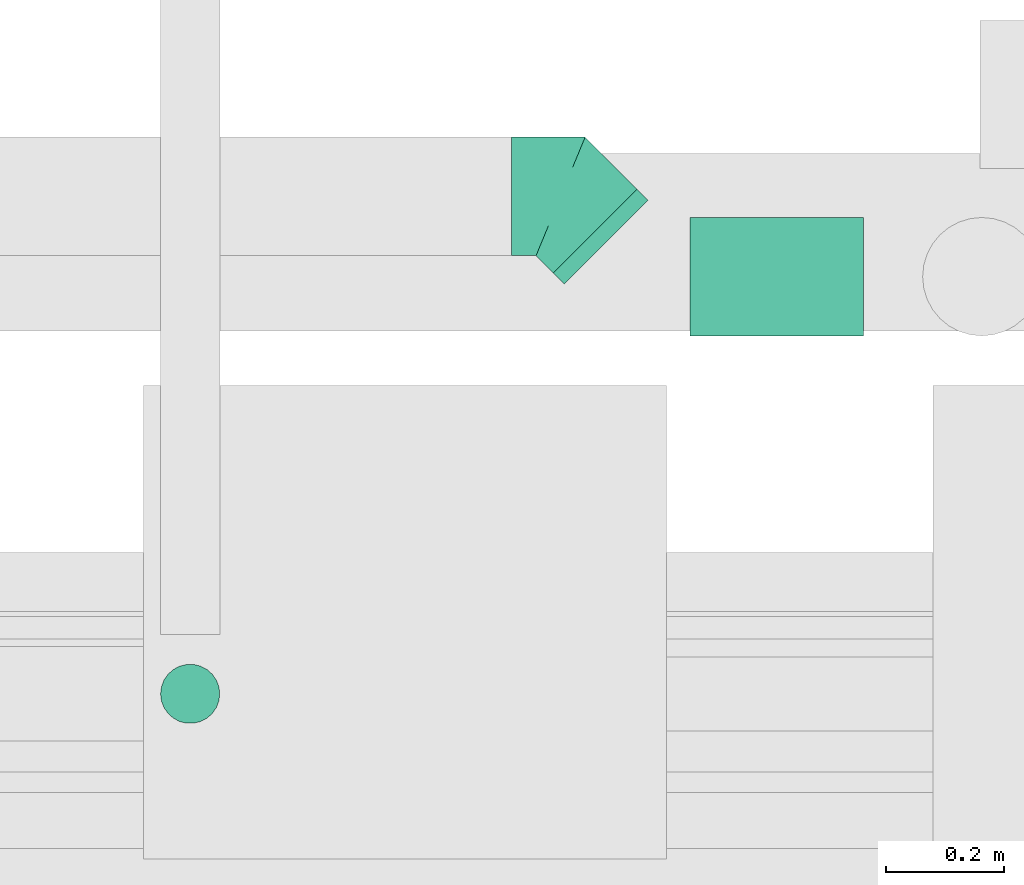
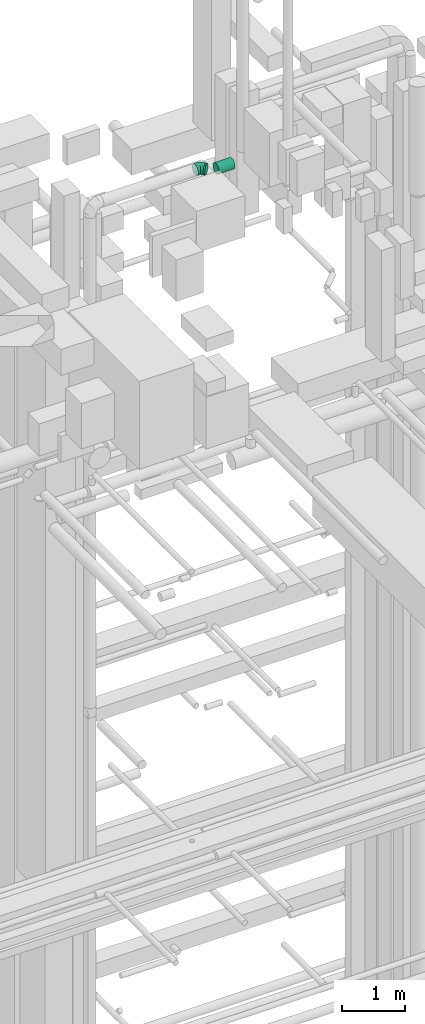
# One storey, part 131 of 337: 3 flow segments, 1 flow fitting.
"""IFC2X3 building model written with IfcOpenShell, lengths in millimetres."""

import ifcopenshell
import ifcopenshell.guid

model = None  # the IFC model being written
_history = None  # IfcOwnerHistory: only IFC2X3 demands one
_inside = {}  # id of a spatial element -> (the spatial element, [elements in it])
_under = {}  # id of a project, library or spatial element -> (it, [spatial elements below it])
_declared = {}  # id of a project -> (the project, [libraries it declares])
_typed = {}  # id of a type object -> (the type object, [elements of that type])
_made_of = {}  # id of a material, layer set ... -> (it, [elements and type objects made of it])


def new_model(schema):
    """Start an empty IFC model of exactly this schema.

    Asked for "IFC4X3", IfcOpenShell would pick the latest addendum, in which some entities
    have other attributes; the version numbers below select the first issue.
    IFC2X3 requires an IfcOwnerHistory on every rooted entity: one is made here for all.
    """
    global model, _history
    if schema == "IFC4X3":
        model = ifcopenshell.file(schema_version=(4, 3, 0, 0))
    else:
        model = ifcopenshell.file(schema=schema)
    _inside.clear()
    _under.clear()
    _declared.clear()
    _typed.clear()
    _made_of.clear()
    _history = None
    if model.schema == "IFC2X3":
        org = make("IfcOrganization", Name="unknown")
        user = make(
            "IfcPersonAndOrganization",
            ThePerson=make("IfcPerson", FamilyName="unknown"),
            TheOrganization=org,
        )
        app = make(
            "IfcApplication",
            ApplicationDeveloper=org,
            Version="unknown",
            ApplicationFullName="unknown",
            ApplicationIdentifier="unknown",
        )
        _history = make(
            "IfcOwnerHistory",
            OwningUser=user,
            OwningApplication=app,
            ChangeAction="ADDED",
            CreationDate=0,
        )
    return model


def make(cls, **values):
    """One entity of the class cls with the attributes given. An attribute that is None is left unset."""
    return model.create_entity(
        cls, **{name: value for name, value in values.items() if value is not None}
    )


def entity(cls, *values):
    """Any entity or typed value of the class cls, its attributes in the order of the schema. None: left unset."""
    e = model.create_entity(cls)
    for i, value in enumerate(values):
        if value is not None:
            e[i] = value
    return e


def rooted(cls, **values):
    """An entity with a GlobalId (a new one), such as an element, a storey or a relation."""
    return make(cls, GlobalId=ifcopenshell.guid.new(), OwnerHistory=_history, **values)


def si_unit(unit_type, name, prefix=None):
    """IfcSIUnit, for example si_unit("LENGTHUNIT", "METRE", prefix="MILLI")."""
    return make("IfcSIUnit", UnitType=unit_type, Prefix=prefix, Name=name)


def converted_unit(unit_type, name, factor, base, dimensions=None, offset=None):
    """IfcConversionBasedUnit, such as the inch: factor (a typed value) times the base unit."""
    return make(
        "IfcConversionBasedUnit"
        if offset is None
        else "IfcConversionBasedUnitWithOffset",
        ConversionOffset=offset,
        Dimensions=None
        if dimensions is None
        else entity("IfcDimensionalExponents", *dimensions),
        UnitType=unit_type,
        Name=name,
        ConversionFactor=make(
            "IfcMeasureWithUnit", ValueComponent=factor, UnitComponent=base
        ),
    )


def derived_unit(unit_type, elements):
    """IfcDerivedUnit: a product of units, each with its exponent."""
    return make(
        "IfcDerivedUnit",
        Elements=[
            make("IfcDerivedUnitElement", Unit=unit, Exponent=power)
            for unit, power in elements
        ],
        UnitType=unit_type,
    )


def assignment(units):
    """IfcUnitAssignment: the units of a project."""
    return None if units is None else make("IfcUnitAssignment", Units=units)


def point(xyz):
    """IfcCartesianPoint."""
    return None if xyz is None else make("IfcCartesianPoint", Coordinates=xyz)


def direction(xyz):
    """IfcDirection."""
    return None if xyz is None else make("IfcDirection", DirectionRatios=xyz)


def frame(location, z_axis=None, x_axis=None):
    """IfcAxis2Placement3D, a coordinate frame: its origin and axes. An axis left out is left unset."""
    return make(
        "IfcAxis2Placement3D",
        Location=point(location),
        Axis=direction(z_axis),
        RefDirection=direction(x_axis),
    )


def frame_2d(location, x_axis=None):
    """IfcAxis2Placement2D, a coordinate frame in the plane: its origin and x axis."""
    return make(
        "IfcAxis2Placement2D", Location=point(location), RefDirection=direction(x_axis)
    )


def origin():
    """The frame at (0, 0, 0) with its axes left unset."""
    return frame((0.0, 0.0, 0.0))


def origin_2d_with_axis():
    """The frame at (0, 0) in the plane with the x axis (1, 0) written out."""
    return frame_2d((0.0, 0.0), x_axis=(1.0, 0.0))


def place(relative_to, where):
    """IfcLocalPlacement: puts the frame where relative to a parent placement (None: the world)."""
    return make(
        "IfcLocalPlacement", PlacementRelTo=relative_to, RelativePlacement=where
    )


def context(
    kind, dimensions, precision=None, world=None, true_north=None, identifier=None
):
    """IfcGeometricRepresentationContext, for example the 3D "Model" context."""
    return make(
        "IfcGeometricRepresentationContext",
        ContextIdentifier=identifier,
        ContextType=kind,
        CoordinateSpaceDimension=dimensions,
        Precision=precision,
        WorldCoordinateSystem=world,
        TrueNorth=true_north,
    )


def subcontext(parent, identifier, kind, view, scale=None):
    """IfcGeometricRepresentationSubContext, for example "Body" below "Model"."""
    return make(
        "IfcGeometricRepresentationSubContext",
        ContextIdentifier=identifier,
        ContextType=kind,
        ParentContext=parent,
        TargetScale=scale,
        TargetView=view,
    )


def project(units=None, contexts=None):
    """IfcProject with its units and contexts."""
    return rooted(
        "IfcProject",
        Name="project",
        RepresentationContexts=contexts,
        UnitsInContext=assignment(units),
    )


def spatial(cls, under=None, at=None, **own):
    """A site, building, storey or space (cls), placed at a placement, below another one or the project."""
    s = rooted(cls, ObjectPlacement=at, **own)
    if under is not None:
        _under.setdefault(under.id(), (under, []))[1].append(s)
    return s


def profile(cls, at=None, kind="AREA", **sizes):
    """A parametric profile (cls). Its sizes go by their IFC names, for example OverallWidth=200.0."""
    return make(cls, ProfileType=kind, Position=at, **sizes)


def circle(**sizes):
    """IfcCircleProfileDef."""
    return profile("IfcCircleProfileDef", **sizes)


def extrude(swept, where, along, depth):
    """IfcExtrudedAreaSolid: the profile swept, set in the frame where, extruded along a direction by depth."""
    return make(
        "IfcExtrudedAreaSolid",
        SweptArea=swept,
        Position=where,
        ExtrudedDirection=direction(along),
        Depth=depth,
    )


def faces_of(points, faces, orient=None, outer=None):
    """IfcFace entities. A face is a list of loops; a loop is a list of indices into points, from 0.

    orient and outer hold one flag for each loop. By default every Orientation is true, the
    first loop of a face is its IfcFaceOuterBound and the others are IfcFaceBound.
    """
    made = []
    for i, loops in enumerate(faces):
        bounds = []
        for j, loop in enumerate(loops):
            is_outer = j == 0 if outer is None else outer[i][j]
            bounds.append(
                make(
                    "IfcFaceOuterBound" if is_outer else "IfcFaceBound",
                    Bound=make("IfcPolyLoop", Polygon=[points[k] for k in loop]),
                    Orientation=True if orient is None else orient[i][j],
                )
            )
        made.append(make("IfcFace", Bounds=bounds))
    return made


def faceted_brep(points, faces, orient=None, outer=None, voids=None):
    """IfcFacetedBrep: a solid bounded by flat faces; with voids (closed shells), ...WithVoids."""
    shared = [point(p) for p in points]
    hull = make("IfcClosedShell", CfsFaces=faces_of(shared, faces, orient, outer))
    if voids is None:
        return make("IfcFacetedBrep", Outer=hull)
    return make(
        "IfcFacetedBrepWithVoids",
        Outer=hull,
        Voids=[
            make(cls, CfsFaces=faces_of(shared, fs, o, b)) for cls, fs, o, b in voids
        ],
    )


def shape(context_of_items, identifier, shape_type, items):
    """IfcShapeRepresentation: the items that make up one representation, for example the "Body"."""
    return make(
        "IfcShapeRepresentation",
        ContextOfItems=context_of_items,
        RepresentationIdentifier=identifier,
        RepresentationType=shape_type,
        Items=items,
    )


def source(mapping_origin, context_of_items, identifier, shape_type, items):
    """IfcRepresentationMap: a shape defined once, which mapped items show again and again."""
    return make(
        "IfcRepresentationMap",
        MappingOrigin=mapping_origin,
        MappedRepresentation=shape(context_of_items, identifier, shape_type, items),
    )


def transform(
    local_origin,
    x_axis=None,
    y_axis=None,
    z_axis=None,
    scale=None,
    scale2=None,
    scale3=None,
    uniform=True,
):
    """IfcCartesianTransformationOperator3D, or its non-uniform kind. x_axis, y_axis, z_axis: its Axis1, 2, 3."""
    if uniform:
        return make(
            "IfcCartesianTransformationOperator3D",
            Axis1=direction(x_axis),
            Axis2=direction(y_axis),
            LocalOrigin=point(local_origin),
            Scale=scale,
            Axis3=direction(z_axis),
        )
    return make(
        "IfcCartesianTransformationOperator3DnonUniform",
        Axis1=direction(x_axis),
        Axis2=direction(y_axis),
        LocalOrigin=point(local_origin),
        Scale=scale,
        Axis3=direction(z_axis),
        Scale2=scale2,
        Scale3=scale3,
    )


def mapped(mapping_source, mapping_target):
    """IfcMappedItem: shows the shape of a source again, moved by a transform."""
    return make(
        "IfcMappedItem", MappingSource=mapping_source, MappingTarget=mapping_target
    )


def material(Name=None, Category=None):
    """IfcMaterial."""
    return make("IfcMaterial", Name=Name, Category=Category)


def made_of(thing, what):
    """Note that an element or type object is made of a material, layer set ...; save() writes the relation."""
    if what is not None:
        _made_of.setdefault(what.id(), (what, []))[1].append(thing)
    return thing


def type_object(cls, material=None, **own):
    """A type object (cls), such as IfcWallType, which elements share."""
    return made_of(rooted(cls, **own), material)


def type_shapes(of_type, sources):
    """Give a type object the sources (RepresentationMaps) that its elements show as mapped items."""
    of_type.RepresentationMaps = sources


def element(
    cls,
    number,
    at=None,
    inside=None,
    cuts=None,
    type_object=None,
    material=None,
    context=None,
    identifier="Body",
    shape_type=None,
    held_by="IfcProductDefinitionShape",
    body=None,
    shapes=None,
    **own,
):
    """One element of the class cls, such as IfcWall. Its Tag is "e" and its number.

    at: its placement. inside: the storey or other place that contains it. cuts: it is an
    opening in that element (IfcRelVoidsElement). A single representation is given by context,
    identifier, shape_type and body (its items); several are given by shapes. held_by: the class
    of the entity that holds the representations. save() writes the other relations.
    """
    e = rooted(cls, Tag="e%d" % number, ObjectPlacement=at, **own)
    if body is not None:
        shapes = [shape(context, identifier, shape_type, body)]
    if shapes is not None:
        e.Representation = make(held_by, Representations=shapes)
    if inside is not None:
        _inside.setdefault(inside.id(), (inside, []))[1].append(e)
    if cuts is not None:
        rooted(
            "IfcRelVoidsElement", RelatingBuildingElement=cuts, RelatedOpeningElement=e
        )
    if type_object is not None:
        _typed.setdefault(type_object.id(), (type_object, []))[1].append(e)
    return made_of(e, material)


def aggregate(whole, parts):
    """IfcRelAggregates: a whole, such as a stair, and the parts it consists of."""
    return rooted("IfcRelAggregates", RelatingObject=whole, RelatedObjects=parts)


def save(model, path):
    """Write the relations noted so far, then the file.

    IfcRelAggregates (storeys below a building ...), IfcRelContainedInSpatialStructure (elements
    in a storey), IfcRelDefinesByType, IfcRelAssociatesMaterial and IfcRelDeclares: one each for
    every whole, place, type object, material and project.
    """
    for whole, parts in _under.values():
        aggregate(whole, parts)
    for where, things in _inside.values():
        rooted(
            "IfcRelContainedInSpatialStructure",
            RelatedElements=things,
            RelatingStructure=where,
        )
    for kind, things in _typed.values():
        rooted("IfcRelDefinesByType", RelatedObjects=things, RelatingType=kind)
    for what, things in _made_of.values():
        rooted("IfcRelAssociatesMaterial", RelatedObjects=things, RelatingMaterial=what)
    for by, libraries in _declared.values():
        rooted("IfcRelDeclares", RelatingContext=by, RelatedDefinitions=libraries)
    model.write(path)


model = new_model("IFC2X3")

# Units and contexts
model_context = context("Model", 3, precision=0.01, world=origin(), true_north=direction((6.12303176911189e-17, 1.0)))
body_context = subcontext(model_context, "Body", "Model", "MODEL_VIEW")
ifc_project = project(units=[si_unit("LENGTHUNIT", "METRE", prefix="MILLI"), si_unit("AREAUNIT", "SQUARE_METRE"), si_unit("VOLUMEUNIT", "CUBIC_METRE"), converted_unit("PLANEANGLEUNIT", "DEGREE", entity("IfcRatioMeasure", 0.0174532925199433), si_unit("PLANEANGLEUNIT", "RADIAN"), dimensions=[0, 0, 0, 0, 0, 0, 0]), si_unit("MASSUNIT", "GRAM", prefix="KILO"), derived_unit("MASSDENSITYUNIT", [(si_unit("MASSUNIT", "GRAM", prefix="KILO"), 1), (si_unit("LENGTHUNIT", "METRE"), -3)]), derived_unit("MOMENTOFINERTIAUNIT", [(si_unit("LENGTHUNIT", "METRE"), 4)]), si_unit("TIMEUNIT", "SECOND"), si_unit("FREQUENCYUNIT", "HERTZ"), si_unit("THERMODYNAMICTEMPERATUREUNIT", "DEGREE_CELSIUS"), derived_unit("THERMALTRANSMITTANCEUNIT", [(si_unit("MASSUNIT", "GRAM", prefix="KILO"), 1), (si_unit("THERMODYNAMICTEMPERATUREUNIT", "KELVIN"), -1), (si_unit("TIMEUNIT", "SECOND"), -3)]), derived_unit("VOLUMETRICFLOWRATEUNIT", [(si_unit("LENGTHUNIT", "METRE"), 3), (si_unit("TIMEUNIT", "SECOND"), -1)]), derived_unit("MASSFLOWRATEUNIT", [(si_unit("MASSUNIT", "GRAM", prefix="KILO"), 1), (si_unit("TIMEUNIT", "SECOND"), -1)]), derived_unit("ROTATIONALFREQUENCYUNIT", [(si_unit("TIMEUNIT", "SECOND"), -1)]), si_unit("ELECTRICCURRENTUNIT", "AMPERE"), si_unit("ELECTRICVOLTAGEUNIT", "VOLT"), si_unit("POWERUNIT", "WATT"), si_unit("FORCEUNIT", "NEWTON", prefix="KILO"), si_unit("ILLUMINANCEUNIT", "LUX"), si_unit("LUMINOUSFLUXUNIT", "LUMEN"), si_unit("LUMINOUSINTENSITYUNIT", "CANDELA"), derived_unit("USERDEFINED", [(si_unit("MASSUNIT", "GRAM", prefix="KILO"), -1), (si_unit("LENGTHUNIT", "METRE"), -2), (si_unit("TIMEUNIT", "SECOND"), 3), (si_unit("LUMINOUSFLUXUNIT", "LUMEN"), 1)]), derived_unit("LINEARVELOCITYUNIT", [(si_unit("LENGTHUNIT", "METRE"), 1), (si_unit("TIMEUNIT", "SECOND"), -1)]), si_unit("PRESSUREUNIT", "PASCAL"), derived_unit("USERDEFINED", [(si_unit("LENGTHUNIT", "METRE"), -2), (si_unit("MASSUNIT", "GRAM", prefix="KILO"), 1), (si_unit("TIMEUNIT", "SECOND"), -2)]), derived_unit("LINEARFORCEUNIT", [(si_unit("MASSUNIT", "GRAM", prefix="KILO"), 1), (si_unit("LENGTHUNIT", "METRE"), 1), (si_unit("TIMEUNIT", "SECOND"), -2), (si_unit("LENGTHUNIT", "METRE"), -1)]), derived_unit("PLANARFORCEUNIT", [(si_unit("MASSUNIT", "GRAM", prefix="KILO"), 1), (si_unit("LENGTHUNIT", "METRE"), 1), (si_unit("TIMEUNIT", "SECOND"), -2), (si_unit("LENGTHUNIT", "METRE"), -2)])], contexts=[model_context])

# Site, building, storey
site_placement = place(None, origin())
site = spatial("IfcSite", under=ifc_project, at=site_placement, CompositionType="ELEMENT")
building_placement = place(site_placement, origin())
building = spatial("IfcBuilding", under=site, at=building_placement, CompositionType="ELEMENT")
storey_placement = place(building_placement, origin())
storey = spatial("IfcBuildingStorey", under=building, at=storey_placement, CompositionType="ELEMENT", Elevation=0.0)

# Flow segments
duct_segment_type = type_object("IfcDuctSegmentType", PredefinedType="NOTDEFINED")
flow_segment_1_placement = place(storey_placement, frame((26267.94, 10005.52, 19140.0)))
element("IfcFlowSegment", 1, at=flow_segment_1_placement, inside=storey, type_object=duct_segment_type, context=body_context, shape_type="SweptSolid", body=[
    extrude(circle(Radius=50.0, at=origin_2d_with_axis()), frame((51.6, 51.6, 0.0), z_axis=(0.0, 0.0, 1.0), x_axis=(-1.0, 0.0, 0.0)), (0.0, 0.0, 1.0), 9.99999999992409),
])
flow_segment_2_placement = place(storey_placement, frame((26931.63, 10748.19, 31308.51)))
element("IfcFlowSegment", 2, at=flow_segment_2_placement, inside=storey, type_object=duct_segment_type, context=body_context, shape_type="SweptSolid", body=[
    extrude(circle(Radius=100.0, at=origin_2d_with_axis()), frame((90.79, 72.31, 101.6), z_axis=(-0.707106781186465, 0.70710678118663, 0.0), x_axis=(-0.70710678118663, -0.707106781186465, 0.0)), (0.0, 0.0, 1.0), 26.1377888225308),
])
flow_segment_3_placement = place(storey_placement, frame((27163.84, 10660.32, 31308.51)))
element("IfcFlowSegment", 3, at=flow_segment_3_placement, inside=storey, type_object=duct_segment_type, context=body_context, shape_type="SweptSolid", body=[
    extrude(circle(Radius=100.0, at=origin_2d_with_axis()), frame((0.0, 101.6, 101.6), z_axis=(1.0, 0.0, 0.0), x_axis=(0.0, -1.0, 0.0)), (0.0, 0.0, 1.0), 293.132929708071),
])

# Flow fitting
ifc_material = material()
duct_fitting_type = type_object("IfcDuctFittingType", PredefinedType="NOTDEFINED", material=ifc_material)
shared_shape = source(origin(), body_context, "Body", "Brep", [
    faceted_brep([(-82.84, 0.0, -100.0), (-82.84, -25.88, -96.59), (-82.84, -50.0, -86.6), (-82.84, -70.71, -70.71), (-82.84, -86.6, -50.0), (-82.84, -96.59, -25.88), (-82.84, -100.0, 0.0), (-82.84, -96.59, 25.88), (-82.84, -86.6, 50.0), (-82.84, -70.71, 70.71), (-82.84, -50.0, 86.6), (-82.84, -25.88, 96.59), (-82.84, 0.0, 100.0), (-82.84, 25.88, 96.59), (-82.84, 50.0, 86.6), (-82.84, 70.71, 70.71), (-82.84, 86.6, 50.0), (-82.84, 96.59, 25.88), (-82.84, 100.0, 0.0), (-82.84, 96.59, -25.88), (-82.84, 86.6, -50.0), (-82.84, 70.71, -70.71), (-82.84, 50.0, -86.6), (-82.84, 25.88, -96.59), (-10.72, 25.88, 96.59), (-20.71, 50.0, 86.6), (0.0, 0.0, 100.0), (-29.29, 70.71, 70.71), (-35.87, 86.6, 50.0), (-40.01, 96.59, 25.88), (-41.42, 100.0, 0.0), (-40.01, 96.59, -25.88), (-35.87, 86.6, -50.0), (-29.29, 70.71, -70.71), (-10.72, 25.88, -96.59), (0.0, 0.0, -100.0), (-20.71, 50.0, -86.6), (10.72, -25.88, -96.59), (20.71, -50.0, -86.6), (29.29, -70.71, -70.71), (35.87, -86.6, -50.0), (40.01, -96.59, -25.88), (41.42, -100.0, 0.0), (40.01, -96.59, 25.88), (35.87, -86.6, 50.0), (29.29, -70.71, 70.71), (20.71, -50.0, 86.6), (10.72, -25.88, 96.59), (58.58, 58.58, 100.0), (40.28, 76.88, 96.59), (23.22, 93.93, 86.6), (8.58, 108.58, 70.71), (-2.66, 119.82, 50.0), (-9.72, 126.88, 25.88), (-12.13, 129.29, 0.0), (-9.72, 126.88, -25.88), (-2.66, 119.82, -50.0), (8.58, 108.58, -70.71), (23.22, 93.93, -86.6), (40.28, 76.88, -96.59), (58.58, 58.58, -100.0), (76.88, 40.28, -96.59), (93.93, 23.22, -86.6), (108.58, 8.58, -70.71), (119.82, -2.66, -50.0), (126.88, -9.72, -25.88), (129.29, -12.13, 0.0), (126.88, -9.72, 25.88), (119.82, -2.66, 50.0), (108.58, 8.58, 70.71), (93.93, 23.22, 86.6), (76.88, 40.28, 96.59)], [[[0, 1, 2, 3, 4, 5, 6, 7, 8, 9, 10, 11, 12, 13, 14, 15, 16, 17, 18, 19, 20, 21, 22, 23]], [[24, 25, 14, 13]], [[26, 24, 13, 12]], [[14, 25, 27, 15]], [[28, 29, 17, 16]], [[28, 16, 15, 27]], [[30, 18, 17, 29]], [[31, 32, 20, 19]], [[30, 31, 19, 18]], [[32, 33, 21, 20]], [[34, 35, 0, 23]], [[36, 34, 23, 22]], [[33, 36, 22, 21]], [[1, 0, 35, 37]], [[2, 1, 37, 38]], [[38, 39, 3, 2]], [[5, 4, 40, 41]], [[6, 5, 41, 42]], [[39, 40, 4, 3]], [[6, 42, 43, 7]], [[7, 43, 44, 8]], [[8, 44, 45, 9]], [[9, 45, 46, 10]], [[10, 46, 47, 11]], [[26, 12, 11, 47]], [[24, 26, 48, 49]], [[25, 24, 49, 50]], [[27, 25, 50, 51]], [[29, 28, 52, 53]], [[30, 29, 53, 54]], [[51, 52, 28, 27]], [[30, 54, 55, 31]], [[31, 55, 56, 32]], [[57, 33, 32, 56]], [[36, 58, 59, 34]], [[34, 59, 60, 35]], [[58, 36, 33, 57]], [[35, 60, 61, 37]], [[37, 61, 62, 38]], [[63, 39, 38, 62]], [[40, 64, 65, 41]], [[41, 65, 66, 42]], [[64, 40, 39, 63]], [[43, 42, 66, 67]], [[44, 43, 67, 68]], [[68, 69, 45, 44]], [[47, 46, 70, 71]], [[26, 47, 71, 48]], [[69, 70, 46, 45]], [[59, 58, 57, 56, 55, 54, 53, 52, 51, 50, 49, 48, 71, 70, 69, 68, 67, 66, 65, 64, 63, 62, 61, 60]]]),
])
type_shapes(duct_fitting_type, [shared_shape])
flow_fitting_placement = place(storey_placement, frame((26945.35, 10897.55, 31410.11), z_axis=(0.0, 0.0, 1.0), x_axis=(-0.707106781186536, 0.70710678118656, 0.0)))
element("IfcFlowFitting", 4, at=flow_fitting_placement, inside=storey, type_object=duct_fitting_type, material=ifc_material, context=body_context, shape_type="MappedRepresentation", body=[
    mapped(shared_shape, transform((0.0, 0.0, 0.0), scale=1.0)),
])

save(model, "model.ifc")
